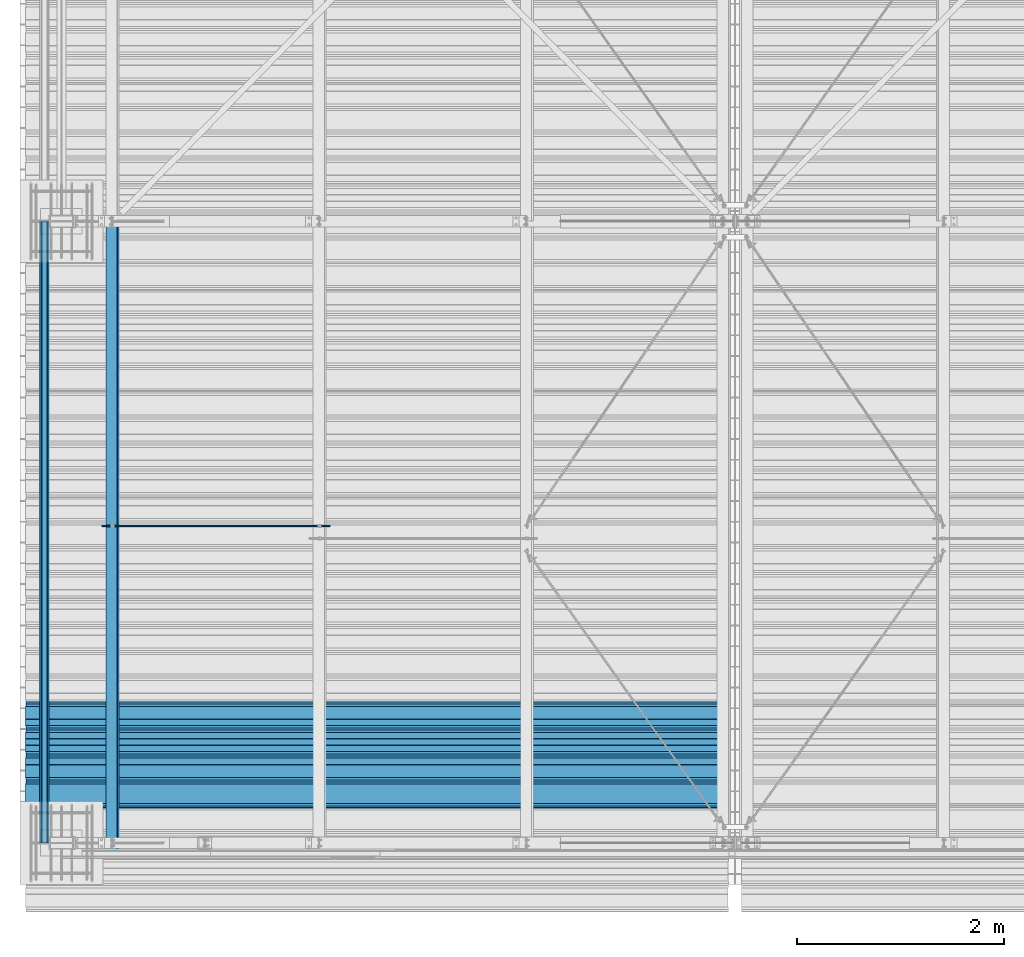
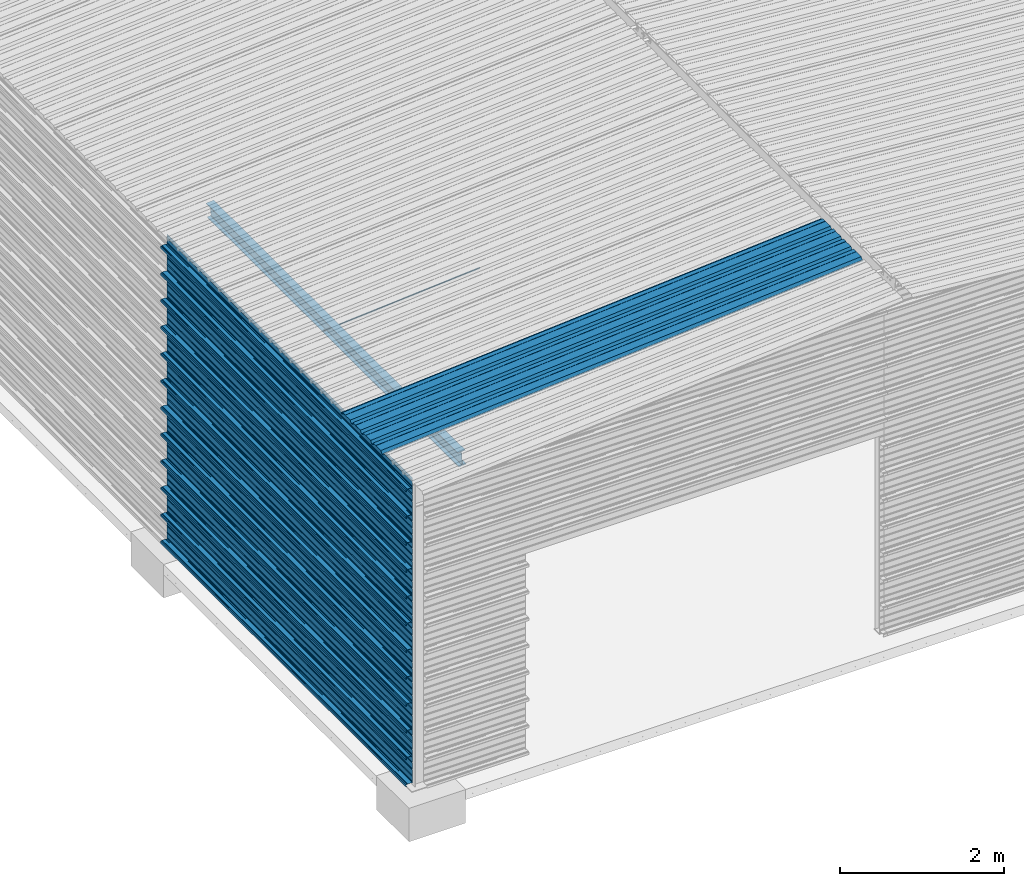
# One storey, part 5 of 70: 15 beams, 15 elements without a shape of their own.
"""IFC2X3 building model written with IfcOpenShell, lengths in millimetres."""

from ifc_helpers import new_model, si_unit, frame, origin_with_axes, origin_2d_with_axis, place, context, subcontext, project, spatial, polyline, circle, i_section, outline, extrude, clip, halfspace, material, type_object, element, aggregate, save


model = new_model("IFC2X3")

# Units and contexts
model_context = context("Model", 3, precision=1e-05, world=origin_with_axes())
body_context = subcontext(model_context, "Body", "Model", "MODEL_VIEW")
ifc_project = project(units=[si_unit("LENGTHUNIT", "METRE", prefix="MILLI"), si_unit("AREAUNIT", "SQUARE_METRE"), si_unit("VOLUMEUNIT", "CUBIC_METRE"), si_unit("MASSUNIT", "GRAM", prefix="KILO"), si_unit("TIMEUNIT", "SECOND"), si_unit("PLANEANGLEUNIT", "RADIAN"), si_unit("SOLIDANGLEUNIT", "STERADIAN"), si_unit("THERMODYNAMICTEMPERATUREUNIT", "DEGREE_CELSIUS"), si_unit("LUMINOUSINTENSITYUNIT", "LUMEN")], contexts=[model_context])

# Site, building, storey
site_placement = place(None, origin_with_axes())
site = spatial("IfcSite", under=ifc_project, at=site_placement, CompositionType="ELEMENT")
building_placement = place(site_placement, origin_with_axes())
building = spatial("IfcBuilding", under=site, at=building_placement, Name="Undefined", CompositionType="ELEMENT")
storey_placement = place(building_placement, origin_with_axes())
storey = spatial("IfcBuildingStorey", under=building, at=storey_placement, Name="Undefined", CompositionType="ELEMENT", Elevation=0.0)

# Assembly, beam
assembly_1_placement = place(storey_placement, origin_with_axes())
assembly_1 = element("IfcElementAssembly", 1, at=assembly_1_placement, inside=storey, Name="Steel Assembly", AssemblyPlace="NOTDEFINED", PredefinedType="RIGID_FRAME")
ifc_material = material(Name="STEEL/S235JR")
beam_type_1 = type_object("IfcBeamType", Name="4.40", PredefinedType="NOTDEFINED")
beam_1_placement = place(assembly_1_placement, frame((6436.39248868039, 850.0, 5336.31760454388), z_axis=(0.0766964990376782, 0.0, -0.997054485489817), x_axis=(-0.997054485489818, 0.0, -0.0766964990376602)))
beam_1 = element("IfcBeam", 2, at=beam_1_placement, type_object=beam_type_1, material=ifc_material, ObjectType="4.40", context=body_context, shape_type="SweptSolid", body=[
    extrude(outline(polyline([(509.415161132813, 19.5000000011705), (490.584838867188, 19.5000000011705), (468.084838867188, -20.4999999988113), (406.585784912109, -20.4999999988113), (404.585784912109, -18.4999999988122), (345.414215087891, -18.4999999988122), (343.414215087891, -20.4999999988113), (281.915161132813, -20.4999999988113), (259.415161132813, 19.5000000011705), (240.584854125977, 19.5000000011705), (218.084854125977, -20.4999999988113), (156.585784912109, -20.4999999988113), (154.585784912109, -18.4999999988122), (95.4142150878906, -18.4999999988122), (93.4142150878906, -20.4999999988113), (31.9151515960693, -20.4999999988113), (9.41515254974365, 19.5000000011705), (-9.41515254974365, 19.5000000011705), (-31.9151515960693, -20.4999999988113), (-93.4142150878906, -20.4999999988113), (-95.4142150878906, -18.4999999988122), (-154.585784912109, -18.4999999988122), (-156.585784912109, -20.4999999988113), (-218.084854125977, -20.4999999988113), (-240.584854125977, 19.5000000011705), (-259.415161132813, 19.5000000011705), (-281.915161132813, -20.4999999988113), (-343.414215087891, -20.4999999988113), (-345.414215087891, -18.4999999988122), (-404.585784912109, -18.4999999988122), (-406.585784912109, -20.4999999988113), (-468.084838867188, -20.4999999988113), (-490.584838867188, 19.5000000011705), (-509.415161132813, 19.5000000011705), (-516.482360839844, 6.9361057293263), (-517.353942871094, 7.42636680720625), (-510.0, 20.5000000011705), (-490.0, 20.5000000011705), (-467.5, -19.4999999988122), (-407.0, -19.4999999988122), (-405.0, -17.4999999988131), (-345.0, -17.4999999988131), (-343.0, -19.4999999988122), (-282.5, -19.4999999988122), (-260.0, 20.5000000011705), (-240.0, 20.5000000011705), (-217.5, -19.4999999988122), (-157.0, -19.4999999988122), (-155.0, -17.4999999988131), (-95.0, -17.4999999988131), (-93.0, -19.4999999988122), (-32.5, -19.4999999988122), (-10.0, 20.5000000011705), (10.0, 20.5000000011705), (32.5, -19.4999999988122), (93.0, -19.4999999988122), (95.0, -17.4999999988131), (155.0, -17.4999999988131), (157.0, -19.4999999988122), (217.5, -19.4999999988122), (240.0, 20.5000000011705), (260.0, 20.5000000011705), (282.5, -19.4999999988122), (343.0, -19.4999999988122), (345.0, -17.4999999988131), (405.0, -17.4999999988131), (407.0, -19.4999999988122), (467.5, -19.4999999988122), (490.0, 20.5000000011705), (510.0, 20.5000000011705), (517.353942871094, 7.42636680720625), (516.482360839844, 6.9361057293263), (509.415161132813, 19.5000000011705)])), frame((6799.99999999733, 2.8421709430404e-14, 0.0), z_axis=(-1.0, 0.0, 0.0), x_axis=(0.0, -1.0, 0.0)), (0.0, 0.0, 1.0), 6800.0),
])
aggregate(assembly_1, [beam_1])

assembly_2_placement = place(storey_placement, origin_with_axes())
assembly_2 = element("IfcElementAssembly", 3, at=assembly_2_placement, inside=storey, Name="Steel Assembly", AssemblyPlace="NOTDEFINED", PredefinedType="RIGID_FRAME")
beam_type_2 = type_object("IfcBeamType", Name="400", PredefinedType="NOTDEFINED")
beam_2_placement = place(assembly_2_placement, frame((-165.499999998334, 3.5811353882309e-12, 4618.17396601053), z_axis=(-1.0, 0.0, 0.0), x_axis=(0.0, 1.0, 0.0)))
beam_2 = element("IfcBeam", 4, at=beam_2_placement, type_object=beam_type_2, material=ifc_material, ObjectType="400", context=body_context, shape_type="Clipping", body=[
    clip(extrude(outline(polyline([(218.25, -24.994083404541), (214.25, -31.8999996185303), (214.25, -45.5), (199.75, -45.5), (194.25, -42.5), (188.75, -45.5), (124.25, -45.5), (114.25, -41.5), (104.25, -45.5), (24.25, -45.5), (14.25, -41.5), (4.25, -45.5), (-75.75, -45.5), (-85.75, -41.5), (-95.75, -45.5), (-160.25, -45.5), (-165.75, -42.5), (-171.25, -45.5), (-185.75, -45.5), (-185.75, -30.711540222168), (-181.75, -23.8111782073975), (-181.75, 23.311637878418), (-185.75, 30.2119998931885), (-185.75, 44.5), (-217.25, 44.5), (-217.25, 34.7999992370605), (-218.25, 34.7999992370605), (-218.25, 45.5), (-184.75, 45.5), (-184.75, 30.480884552002), (-180.75, 23.5805225372314), (-180.75, -24.0800628662109), (-184.75, -30.9804248809814), (-184.75, -44.5), (-171.504989624023, -44.5), (-165.75, -41.360912322998), (-159.995010375977, -44.5), (-95.9425811767578, -44.5), (-85.75, -40.422966003418), (-75.5574188232422, -44.5), (4.05741739273071, -44.5), (14.25, -40.422966003418), (24.4425830841064, -44.5), (104.057418823242, -44.5), (114.25, -40.422966003418), (124.442581176758, -44.5), (188.495010375977, -44.5), (194.25, -41.360912322998), (200.004989624023, -44.5), (213.25, -44.5), (213.25, -31.6313018798828), (217.25, -24.7253856658936), (217.25, 21.7253856658936), (213.25, 28.6313018798828), (213.25, 42.0), (187.25, 42.0), (187.25, 32.5499992370605), (186.25, 32.5499992370605), (186.25, 43.0), (214.25, 43.0), (214.25, 28.8999996185303), (218.25, 21.994083404541), (218.25, -24.994083404541)])), frame((6000.0, 0.0, 0.0), z_axis=(-1.0, 0.0, 0.0), x_axis=(0.0, -1.0, 0.0)), (0.0, 0.0, 1.0), 6000.0), halfspace(frame((5.6843418860808e-14, 36.6804312648874, -45.0000000000003), z_axis=(0.0, -1.0, 0.0), x_axis=(0.0, 0.0, 1.0)), False)),
])
aggregate(assembly_2, [beam_2])

assembly_3_placement = place(storey_placement, origin_with_axes())
assembly_3 = element("IfcElementAssembly", 5, at=assembly_3_placement, inside=storey, Name="Steel Assembly", AssemblyPlace="NOTDEFINED", PredefinedType="RIGID_FRAME")
beam_3_placement = place(assembly_3_placement, frame((-165.499999998485, 3.5811353882309e-12, 4218.17396601053), z_axis=(-1.0, 0.0, 0.0), x_axis=(0.0, 1.0, 0.0)))
beam_3 = element("IfcBeam", 6, at=beam_3_placement, type_object=beam_type_2, material=ifc_material, ObjectType="400", context=body_context, shape_type="SweptSolid", body=[
    extrude(outline(polyline([(218.25, -24.994083404541), (214.25, -31.8999996185303), (214.25, -45.5), (199.75, -45.5), (194.25, -42.5), (188.75, -45.5), (124.25, -45.5), (114.25, -41.5), (104.25, -45.5), (24.25, -45.5), (14.25, -41.5), (4.25, -45.5), (-75.75, -45.5), (-85.75, -41.5), (-95.75, -45.5), (-160.25, -45.5), (-165.75, -42.5), (-171.25, -45.5), (-185.75, -45.5), (-185.75, -30.711540222168), (-181.75, -23.8111782073975), (-181.75, 23.311637878418), (-185.75, 30.2119998931885), (-185.75, 44.5), (-217.25, 44.5), (-217.25, 34.7999992370605), (-218.25, 34.7999992370605), (-218.25, 45.5), (-184.75, 45.5), (-184.75, 30.480884552002), (-180.75, 23.5805225372314), (-180.75, -24.0800628662109), (-184.75, -30.9804248809814), (-184.75, -44.5), (-171.504989624023, -44.5), (-165.75, -41.360912322998), (-159.995010375977, -44.5), (-95.9425811767578, -44.5), (-85.75, -40.422966003418), (-75.5574188232422, -44.5), (4.05741739273071, -44.5), (14.25, -40.422966003418), (24.4425830841064, -44.5), (104.057418823242, -44.5), (114.25, -40.422966003418), (124.442581176758, -44.5), (188.495010375977, -44.5), (194.25, -41.360912322998), (200.004989624023, -44.5), (213.25, -44.5), (213.25, -31.6313018798828), (217.25, -24.7253856658936), (217.25, 21.7253856658936), (213.25, 28.6313018798828), (213.25, 42.0), (187.25, 42.0), (187.25, 32.5499992370605), (186.25, 32.5499992370605), (186.25, 43.0), (214.25, 43.0), (214.25, 28.8999996185303), (218.25, 21.994083404541), (218.25, -24.994083404541)])), frame((6000.0, 0.0, 0.0), z_axis=(-1.0, 0.0, 0.0), x_axis=(0.0, -1.0, 0.0)), (0.0, 0.0, 1.0), 6000.0),
])
aggregate(assembly_3, [beam_3])

assembly_4_placement = place(storey_placement, origin_with_axes())
assembly_4 = element("IfcElementAssembly", 7, at=assembly_4_placement, inside=storey, Name="Steel Assembly", AssemblyPlace="NOTDEFINED", PredefinedType="RIGID_FRAME")
beam_4_placement = place(assembly_4_placement, frame((-165.499999998638, 3.5811353882309e-12, 3818.17396601053), z_axis=(-1.0, 0.0, 0.0), x_axis=(0.0, 1.0, 0.0)))
beam_4 = element("IfcBeam", 8, at=beam_4_placement, type_object=beam_type_2, material=ifc_material, ObjectType="400", context=body_context, shape_type="SweptSolid", body=[
    extrude(outline(polyline([(218.25, -24.994083404541), (214.25, -31.8999996185303), (214.25, -45.5), (199.75, -45.5), (194.25, -42.5), (188.75, -45.5), (124.25, -45.5), (114.25, -41.5), (104.25, -45.5), (24.25, -45.5), (14.25, -41.5), (4.25, -45.5), (-75.75, -45.5), (-85.75, -41.5), (-95.75, -45.5), (-160.25, -45.5), (-165.75, -42.5), (-171.25, -45.5), (-185.75, -45.5), (-185.75, -30.711540222168), (-181.75, -23.8111782073975), (-181.75, 23.311637878418), (-185.75, 30.2119998931885), (-185.75, 44.5), (-217.25, 44.5), (-217.25, 34.7999992370605), (-218.25, 34.7999992370605), (-218.25, 45.5), (-184.75, 45.5), (-184.75, 30.480884552002), (-180.75, 23.5805225372314), (-180.75, -24.0800628662109), (-184.75, -30.9804248809814), (-184.75, -44.5), (-171.504989624023, -44.5), (-165.75, -41.360912322998), (-159.995010375977, -44.5), (-95.9425811767578, -44.5), (-85.75, -40.422966003418), (-75.5574188232422, -44.5), (4.05741739273071, -44.5), (14.25, -40.422966003418), (24.4425830841064, -44.5), (104.057418823242, -44.5), (114.25, -40.422966003418), (124.442581176758, -44.5), (188.495010375977, -44.5), (194.25, -41.360912322998), (200.004989624023, -44.5), (213.25, -44.5), (213.25, -31.6313018798828), (217.25, -24.7253856658936), (217.25, 21.7253856658936), (213.25, 28.6313018798828), (213.25, 42.0), (187.25, 42.0), (187.25, 32.5499992370605), (186.25, 32.5499992370605), (186.25, 43.0), (214.25, 43.0), (214.25, 28.8999996185303), (218.25, 21.994083404541), (218.25, -24.994083404541)])), frame((6000.0, 0.0, 0.0), z_axis=(-1.0, 0.0, 0.0), x_axis=(0.0, -1.0, 0.0)), (0.0, 0.0, 1.0), 6000.0),
])
aggregate(assembly_4, [beam_4])

assembly_5_placement = place(storey_placement, origin_with_axes())
assembly_5 = element("IfcElementAssembly", 9, at=assembly_5_placement, inside=storey, Name="Steel Assembly", AssemblyPlace="NOTDEFINED", PredefinedType="RIGID_FRAME")
beam_5_placement = place(assembly_5_placement, frame((-165.499999998789, 3.5811353882309e-12, 3418.17396601053), z_axis=(-1.0, 0.0, 0.0), x_axis=(0.0, 1.0, 0.0)))
beam_5 = element("IfcBeam", 10, at=beam_5_placement, type_object=beam_type_2, material=ifc_material, ObjectType="400", context=body_context, shape_type="SweptSolid", body=[
    extrude(outline(polyline([(218.25, -24.994083404541), (214.25, -31.8999996185303), (214.25, -45.5), (199.75, -45.5), (194.25, -42.5), (188.75, -45.5), (124.25, -45.5), (114.25, -41.5), (104.25, -45.5), (24.25, -45.5), (14.25, -41.5), (4.25, -45.5), (-75.75, -45.5), (-85.75, -41.5), (-95.75, -45.5), (-160.25, -45.5), (-165.75, -42.5), (-171.25, -45.5), (-185.75, -45.5), (-185.75, -30.711540222168), (-181.75, -23.8111782073975), (-181.75, 23.311637878418), (-185.75, 30.2119998931885), (-185.75, 44.5), (-217.25, 44.5), (-217.25, 34.7999992370605), (-218.25, 34.7999992370605), (-218.25, 45.5), (-184.75, 45.5), (-184.75, 30.480884552002), (-180.75, 23.5805225372314), (-180.75, -24.0800628662109), (-184.75, -30.9804248809814), (-184.75, -44.5), (-171.504989624023, -44.5), (-165.75, -41.360912322998), (-159.995010375977, -44.5), (-95.9425811767578, -44.5), (-85.75, -40.422966003418), (-75.5574188232422, -44.5), (4.05741739273071, -44.5), (14.25, -40.422966003418), (24.4425830841064, -44.5), (104.057418823242, -44.5), (114.25, -40.422966003418), (124.442581176758, -44.5), (188.495010375977, -44.5), (194.25, -41.360912322998), (200.004989624023, -44.5), (213.25, -44.5), (213.25, -31.6313018798828), (217.25, -24.7253856658936), (217.25, 21.7253856658936), (213.25, 28.6313018798828), (213.25, 42.0), (187.25, 42.0), (187.25, 32.5499992370605), (186.25, 32.5499992370605), (186.25, 43.0), (214.25, 43.0), (214.25, 28.8999996185303), (218.25, 21.994083404541), (218.25, -24.994083404541)])), frame((6000.0, 0.0, 0.0), z_axis=(-1.0, 0.0, 0.0), x_axis=(0.0, -1.0, 0.0)), (0.0, 0.0, 1.0), 6000.0),
])
aggregate(assembly_5, [beam_5])

assembly_6_placement = place(storey_placement, origin_with_axes())
assembly_6 = element("IfcElementAssembly", 11, at=assembly_6_placement, inside=storey, Name="Steel Assembly", AssemblyPlace="NOTDEFINED", PredefinedType="RIGID_FRAME")
beam_6_placement = place(assembly_6_placement, frame((-165.49999999894, 3.5811353882309e-12, 3018.17396601053), z_axis=(-1.0, 0.0, 0.0), x_axis=(0.0, 1.0, 0.0)))
beam_6 = element("IfcBeam", 12, at=beam_6_placement, type_object=beam_type_2, material=ifc_material, ObjectType="400", context=body_context, shape_type="SweptSolid", body=[
    extrude(outline(polyline([(218.25, -24.994083404541), (214.25, -31.8999996185303), (214.25, -45.5), (199.75, -45.5), (194.25, -42.5), (188.75, -45.5), (124.25, -45.5), (114.25, -41.5), (104.25, -45.5), (24.25, -45.5), (14.25, -41.5), (4.25, -45.5), (-75.75, -45.5), (-85.75, -41.5), (-95.75, -45.5), (-160.25, -45.5), (-165.75, -42.5), (-171.25, -45.5), (-185.75, -45.5), (-185.75, -30.711540222168), (-181.75, -23.8111782073975), (-181.75, 23.311637878418), (-185.75, 30.2119998931885), (-185.75, 44.5), (-217.25, 44.5), (-217.25, 34.7999992370605), (-218.25, 34.7999992370605), (-218.25, 45.5), (-184.75, 45.5), (-184.75, 30.480884552002), (-180.75, 23.5805225372314), (-180.75, -24.0800628662109), (-184.75, -30.9804248809814), (-184.75, -44.5), (-171.504989624023, -44.5), (-165.75, -41.360912322998), (-159.995010375977, -44.5), (-95.9425811767578, -44.5), (-85.75, -40.422966003418), (-75.5574188232422, -44.5), (4.05741739273071, -44.5), (14.25, -40.422966003418), (24.4425830841064, -44.5), (104.057418823242, -44.5), (114.25, -40.422966003418), (124.442581176758, -44.5), (188.495010375977, -44.5), (194.25, -41.360912322998), (200.004989624023, -44.5), (213.25, -44.5), (213.25, -31.6313018798828), (217.25, -24.7253856658936), (217.25, 21.7253856658936), (213.25, 28.6313018798828), (213.25, 42.0), (187.25, 42.0), (187.25, 32.5499992370605), (186.25, 32.5499992370605), (186.25, 43.0), (214.25, 43.0), (214.25, 28.8999996185303), (218.25, 21.994083404541), (218.25, -24.994083404541)])), frame((6000.0, 0.0, 0.0), z_axis=(-1.0, 0.0, 0.0), x_axis=(0.0, -1.0, 0.0)), (0.0, 0.0, 1.0), 6000.0),
])
aggregate(assembly_6, [beam_6])

assembly_7_placement = place(storey_placement, origin_with_axes())
assembly_7 = element("IfcElementAssembly", 13, at=assembly_7_placement, inside=storey, Name="Steel Assembly", AssemblyPlace="NOTDEFINED", PredefinedType="RIGID_FRAME")
beam_7_placement = place(assembly_7_placement, frame((-165.499999999092, 3.5811353882309e-12, 2618.17396601053), z_axis=(-1.0, 0.0, 0.0), x_axis=(0.0, 1.0, 0.0)))
beam_7 = element("IfcBeam", 14, at=beam_7_placement, type_object=beam_type_2, material=ifc_material, ObjectType="400", context=body_context, shape_type="SweptSolid", body=[
    extrude(outline(polyline([(218.25, -24.994083404541), (214.25, -31.8999996185303), (214.25, -45.5), (199.75, -45.5), (194.25, -42.5), (188.75, -45.5), (124.25, -45.5), (114.25, -41.5), (104.25, -45.5), (24.25, -45.5), (14.25, -41.5), (4.25, -45.5), (-75.75, -45.5), (-85.75, -41.5), (-95.75, -45.5), (-160.25, -45.5), (-165.75, -42.5), (-171.25, -45.5), (-185.75, -45.5), (-185.75, -30.711540222168), (-181.75, -23.8111782073975), (-181.75, 23.311637878418), (-185.75, 30.2119998931885), (-185.75, 44.5), (-217.25, 44.5), (-217.25, 34.7999992370605), (-218.25, 34.7999992370605), (-218.25, 45.5), (-184.75, 45.5), (-184.75, 30.480884552002), (-180.75, 23.5805225372314), (-180.75, -24.0800628662109), (-184.75, -30.9804248809814), (-184.75, -44.5), (-171.504989624023, -44.5), (-165.75, -41.360912322998), (-159.995010375977, -44.5), (-95.9425811767578, -44.5), (-85.75, -40.422966003418), (-75.5574188232422, -44.5), (4.05741739273071, -44.5), (14.25, -40.422966003418), (24.4425830841064, -44.5), (104.057418823242, -44.5), (114.25, -40.422966003418), (124.442581176758, -44.5), (188.495010375977, -44.5), (194.25, -41.360912322998), (200.004989624023, -44.5), (213.25, -44.5), (213.25, -31.6313018798828), (217.25, -24.7253856658936), (217.25, 21.7253856658936), (213.25, 28.6313018798828), (213.25, 42.0), (187.25, 42.0), (187.25, 32.5499992370605), (186.25, 32.5499992370605), (186.25, 43.0), (214.25, 43.0), (214.25, 28.8999996185303), (218.25, 21.994083404541), (218.25, -24.994083404541)])), frame((6000.0, 0.0, 0.0), z_axis=(-1.0, 0.0, 0.0), x_axis=(0.0, -1.0, 0.0)), (0.0, 0.0, 1.0), 6000.0),
])
aggregate(assembly_7, [beam_7])

assembly_8_placement = place(storey_placement, origin_with_axes())
assembly_8 = element("IfcElementAssembly", 15, at=assembly_8_placement, inside=storey, Name="Steel Assembly", AssemblyPlace="NOTDEFINED", PredefinedType="RIGID_FRAME")
beam_8_placement = place(assembly_8_placement, frame((-165.499999999243, 3.5811353882309e-12, 2218.17396601053), z_axis=(-1.0, 0.0, 0.0), x_axis=(0.0, 1.0, 0.0)))
beam_8 = element("IfcBeam", 16, at=beam_8_placement, type_object=beam_type_2, material=ifc_material, ObjectType="400", context=body_context, shape_type="SweptSolid", body=[
    extrude(outline(polyline([(218.25, -24.994083404541), (214.25, -31.8999996185303), (214.25, -45.5), (199.75, -45.5), (194.25, -42.5), (188.75, -45.5), (124.25, -45.5), (114.25, -41.5), (104.25, -45.5), (24.25, -45.5), (14.25, -41.5), (4.25, -45.5), (-75.75, -45.5), (-85.75, -41.5), (-95.75, -45.5), (-160.25, -45.5), (-165.75, -42.5), (-171.25, -45.5), (-185.75, -45.5), (-185.75, -30.711540222168), (-181.75, -23.8111782073975), (-181.75, 23.311637878418), (-185.75, 30.2119998931885), (-185.75, 44.5), (-217.25, 44.5), (-217.25, 34.7999992370605), (-218.25, 34.7999992370605), (-218.25, 45.5), (-184.75, 45.5), (-184.75, 30.480884552002), (-180.75, 23.5805225372314), (-180.75, -24.0800628662109), (-184.75, -30.9804248809814), (-184.75, -44.5), (-171.504989624023, -44.5), (-165.75, -41.360912322998), (-159.995010375977, -44.5), (-95.9425811767578, -44.5), (-85.75, -40.422966003418), (-75.5574188232422, -44.5), (4.05741739273071, -44.5), (14.25, -40.422966003418), (24.4425830841064, -44.5), (104.057418823242, -44.5), (114.25, -40.422966003418), (124.442581176758, -44.5), (188.495010375977, -44.5), (194.25, -41.360912322998), (200.004989624023, -44.5), (213.25, -44.5), (213.25, -31.6313018798828), (217.25, -24.7253856658936), (217.25, 21.7253856658936), (213.25, 28.6313018798828), (213.25, 42.0), (187.25, 42.0), (187.25, 32.5499992370605), (186.25, 32.5499992370605), (186.25, 43.0), (214.25, 43.0), (214.25, 28.8999996185303), (218.25, 21.994083404541), (218.25, -24.994083404541)])), frame((6000.0, 0.0, 0.0), z_axis=(-1.0, 0.0, 0.0), x_axis=(0.0, -1.0, 0.0)), (0.0, 0.0, 1.0), 6000.0),
])
aggregate(assembly_8, [beam_8])

assembly_9_placement = place(storey_placement, origin_with_axes())
assembly_9 = element("IfcElementAssembly", 17, at=assembly_9_placement, inside=storey, Name="Steel Assembly", AssemblyPlace="NOTDEFINED", PredefinedType="RIGID_FRAME")
beam_9_placement = place(assembly_9_placement, frame((-165.499999999396, 3.5811353882309e-12, 1818.17396601053), z_axis=(-1.0, 0.0, 0.0), x_axis=(0.0, 1.0, 0.0)))
beam_9 = element("IfcBeam", 18, at=beam_9_placement, type_object=beam_type_2, material=ifc_material, ObjectType="400", context=body_context, shape_type="SweptSolid", body=[
    extrude(outline(polyline([(218.25, -24.994083404541), (214.25, -31.8999996185303), (214.25, -45.5), (199.75, -45.5), (194.25, -42.5), (188.75, -45.5), (124.25, -45.5), (114.25, -41.5), (104.25, -45.5), (24.25, -45.5), (14.25, -41.5), (4.25, -45.5), (-75.75, -45.5), (-85.75, -41.5), (-95.75, -45.5), (-160.25, -45.5), (-165.75, -42.5), (-171.25, -45.5), (-185.75, -45.5), (-185.75, -30.711540222168), (-181.75, -23.8111782073975), (-181.75, 23.311637878418), (-185.75, 30.2119998931885), (-185.75, 44.5), (-217.25, 44.5), (-217.25, 34.7999992370605), (-218.25, 34.7999992370605), (-218.25, 45.5), (-184.75, 45.5), (-184.75, 30.480884552002), (-180.75, 23.5805225372314), (-180.75, -24.0800628662109), (-184.75, -30.9804248809814), (-184.75, -44.5), (-171.504989624023, -44.5), (-165.75, -41.360912322998), (-159.995010375977, -44.5), (-95.9425811767578, -44.5), (-85.75, -40.422966003418), (-75.5574188232422, -44.5), (4.05741739273071, -44.5), (14.25, -40.422966003418), (24.4425830841064, -44.5), (104.057418823242, -44.5), (114.25, -40.422966003418), (124.442581176758, -44.5), (188.495010375977, -44.5), (194.25, -41.360912322998), (200.004989624023, -44.5), (213.25, -44.5), (213.25, -31.6313018798828), (217.25, -24.7253856658936), (217.25, 21.7253856658936), (213.25, 28.6313018798828), (213.25, 42.0), (187.25, 42.0), (187.25, 32.5499992370605), (186.25, 32.5499992370605), (186.25, 43.0), (214.25, 43.0), (214.25, 28.8999996185303), (218.25, 21.994083404541), (218.25, -24.994083404541)])), frame((6000.0, 0.0, 0.0), z_axis=(-1.0, 0.0, 0.0), x_axis=(0.0, -1.0, 0.0)), (0.0, 0.0, 1.0), 6000.0),
])
aggregate(assembly_9, [beam_9])

assembly_10_placement = place(storey_placement, origin_with_axes())
assembly_10 = element("IfcElementAssembly", 19, at=assembly_10_placement, inside=storey, Name="Steel Assembly", AssemblyPlace="NOTDEFINED", PredefinedType="RIGID_FRAME")
beam_10_placement = place(assembly_10_placement, frame((-165.499999999547, 3.5811353882309e-12, 1418.17396601053), z_axis=(-1.0, 0.0, 0.0), x_axis=(0.0, 1.0, 0.0)))
beam_10 = element("IfcBeam", 20, at=beam_10_placement, type_object=beam_type_2, material=ifc_material, ObjectType="400", context=body_context, shape_type="SweptSolid", body=[
    extrude(outline(polyline([(218.25, -24.994083404541), (214.25, -31.8999996185303), (214.25, -45.5), (199.75, -45.5), (194.25, -42.5), (188.75, -45.5), (124.25, -45.5), (114.25, -41.5), (104.25, -45.5), (24.25, -45.5), (14.25, -41.5), (4.25, -45.5), (-75.75, -45.5), (-85.75, -41.5), (-95.75, -45.5), (-160.25, -45.5), (-165.75, -42.5), (-171.25, -45.5), (-185.75, -45.5), (-185.75, -30.711540222168), (-181.75, -23.8111782073975), (-181.75, 23.311637878418), (-185.75, 30.2119998931885), (-185.75, 44.5), (-217.25, 44.5), (-217.25, 34.7999992370605), (-218.25, 34.7999992370605), (-218.25, 45.5), (-184.75, 45.5), (-184.75, 30.480884552002), (-180.75, 23.5805225372314), (-180.75, -24.0800628662109), (-184.75, -30.9804248809814), (-184.75, -44.5), (-171.504989624023, -44.5), (-165.75, -41.360912322998), (-159.995010375977, -44.5), (-95.9425811767578, -44.5), (-85.75, -40.422966003418), (-75.5574188232422, -44.5), (4.05741739273071, -44.5), (14.25, -40.422966003418), (24.4425830841064, -44.5), (104.057418823242, -44.5), (114.25, -40.422966003418), (124.442581176758, -44.5), (188.495010375977, -44.5), (194.25, -41.360912322998), (200.004989624023, -44.5), (213.25, -44.5), (213.25, -31.6313018798828), (217.25, -24.7253856658936), (217.25, 21.7253856658936), (213.25, 28.6313018798828), (213.25, 42.0), (187.25, 42.0), (187.25, 32.5499992370605), (186.25, 32.5499992370605), (186.25, 43.0), (214.25, 43.0), (214.25, 28.8999996185303), (218.25, 21.994083404541), (218.25, -24.994083404541)])), frame((6000.0, 0.0, 0.0), z_axis=(-1.0, 0.0, 0.0), x_axis=(0.0, -1.0, 0.0)), (0.0, 0.0, 1.0), 6000.0),
])
aggregate(assembly_10, [beam_10])

assembly_11_placement = place(storey_placement, origin_with_axes())
assembly_11 = element("IfcElementAssembly", 21, at=assembly_11_placement, inside=storey, Name="Steel Assembly", AssemblyPlace="NOTDEFINED", PredefinedType="RIGID_FRAME")
beam_11_placement = place(assembly_11_placement, frame((-165.499999999698, 3.5811353882309e-12, 1018.17396601053), z_axis=(-1.0, 0.0, 0.0), x_axis=(0.0, 1.0, 0.0)))
beam_11 = element("IfcBeam", 22, at=beam_11_placement, type_object=beam_type_2, material=ifc_material, ObjectType="400", context=body_context, shape_type="SweptSolid", body=[
    extrude(outline(polyline([(218.25, -24.994083404541), (214.25, -31.8999996185303), (214.25, -45.5), (199.75, -45.5), (194.25, -42.5), (188.75, -45.5), (124.25, -45.5), (114.25, -41.5), (104.25, -45.5), (24.25, -45.5), (14.25, -41.5), (4.25, -45.5), (-75.75, -45.5), (-85.75, -41.5), (-95.75, -45.5), (-160.25, -45.5), (-165.75, -42.5), (-171.25, -45.5), (-185.75, -45.5), (-185.75, -30.711540222168), (-181.75, -23.8111782073975), (-181.75, 23.311637878418), (-185.75, 30.2119998931885), (-185.75, 44.5), (-217.25, 44.5), (-217.25, 34.7999992370605), (-218.25, 34.7999992370605), (-218.25, 45.5), (-184.75, 45.5), (-184.75, 30.480884552002), (-180.75, 23.5805225372314), (-180.75, -24.0800628662109), (-184.75, -30.9804248809814), (-184.75, -44.5), (-171.504989624023, -44.5), (-165.75, -41.360912322998), (-159.995010375977, -44.5), (-95.9425811767578, -44.5), (-85.75, -40.422966003418), (-75.5574188232422, -44.5), (4.05741739273071, -44.5), (14.25, -40.422966003418), (24.4425830841064, -44.5), (104.057418823242, -44.5), (114.25, -40.422966003418), (124.442581176758, -44.5), (188.495010375977, -44.5), (194.25, -41.360912322998), (200.004989624023, -44.5), (213.25, -44.5), (213.25, -31.6313018798828), (217.25, -24.7253856658936), (217.25, 21.7253856658936), (213.25, 28.6313018798828), (213.25, 42.0), (187.25, 42.0), (187.25, 32.5499992370605), (186.25, 32.5499992370605), (186.25, 43.0), (214.25, 43.0), (214.25, 28.8999996185303), (218.25, 21.994083404541), (218.25, -24.994083404541)])), frame((6000.0, 0.0, 0.0), z_axis=(-1.0, 0.0, 0.0), x_axis=(0.0, -1.0, 0.0)), (0.0, 0.0, 1.0), 6000.0),
])
aggregate(assembly_11, [beam_11])

assembly_12_placement = place(storey_placement, origin_with_axes())
assembly_12 = element("IfcElementAssembly", 23, at=assembly_12_placement, inside=storey, Name="Steel Assembly", AssemblyPlace="NOTDEFINED", PredefinedType="RIGID_FRAME")
beam_12_placement = place(assembly_12_placement, frame((-165.499999999851, 3.5811353882309e-12, 618.173966010527), z_axis=(-1.0, 0.0, 0.0), x_axis=(0.0, 1.0, 0.0)))
beam_12 = element("IfcBeam", 24, at=beam_12_placement, type_object=beam_type_2, material=ifc_material, ObjectType="400", context=body_context, shape_type="SweptSolid", body=[
    extrude(outline(polyline([(218.25, -24.994083404541), (214.25, -31.8999996185303), (214.25, -45.5), (199.75, -45.5), (194.25, -42.5), (188.75, -45.5), (124.25, -45.5), (114.25, -41.5), (104.25, -45.5), (24.25, -45.5), (14.25, -41.5), (4.25, -45.5), (-75.75, -45.5), (-85.75, -41.5), (-95.75, -45.5), (-160.25, -45.5), (-165.75, -42.5), (-171.25, -45.5), (-185.75, -45.5), (-185.75, -30.711540222168), (-181.75, -23.8111782073975), (-181.75, 23.311637878418), (-185.75, 30.2119998931885), (-185.75, 44.5), (-217.25, 44.5), (-217.25, 34.7999992370605), (-218.25, 34.7999992370605), (-218.25, 45.5), (-184.75, 45.5), (-184.75, 30.480884552002), (-180.75, 23.5805225372314), (-180.75, -24.0800628662109), (-184.75, -30.9804248809814), (-184.75, -44.5), (-171.504989624023, -44.5), (-165.75, -41.360912322998), (-159.995010375977, -44.5), (-95.9425811767578, -44.5), (-85.75, -40.422966003418), (-75.5574188232422, -44.5), (4.05741739273071, -44.5), (14.25, -40.422966003418), (24.4425830841064, -44.5), (104.057418823242, -44.5), (114.25, -40.422966003418), (124.442581176758, -44.5), (188.495010375977, -44.5), (194.25, -41.360912322998), (200.004989624023, -44.5), (213.25, -44.5), (213.25, -31.6313018798828), (217.25, -24.7253856658936), (217.25, 21.7253856658936), (213.25, 28.6313018798828), (213.25, 42.0), (187.25, 42.0), (187.25, 32.5499992370605), (186.25, 32.5499992370605), (186.25, 43.0), (214.25, 43.0), (214.25, 28.8999996185303), (218.25, 21.994083404541), (218.25, -24.994083404541)])), frame((6000.0, 0.0, 0.0), z_axis=(-1.0, 0.0, 0.0), x_axis=(0.0, -1.0, 0.0)), (0.0, 0.0, 1.0), 6000.0),
])
aggregate(assembly_12, [beam_12])

assembly_13_placement = place(storey_placement, origin_with_axes())
assembly_13 = element("IfcElementAssembly", 25, at=assembly_13_placement, inside=storey, Name="Steel Assembly", AssemblyPlace="NOTDEFINED", PredefinedType="RIGID_FRAME")
beam_13_placement = place(assembly_13_placement, frame((-165.500000000002, 3.5811353882309e-12, 218.173966010527), z_axis=(-1.0, 0.0, 0.0), x_axis=(0.0, 1.0, 0.0)))
beam_13 = element("IfcBeam", 26, at=beam_13_placement, type_object=beam_type_2, material=ifc_material, ObjectType="400", context=body_context, shape_type="SweptSolid", body=[
    extrude(outline(polyline([(218.25, -24.994083404541), (214.25, -31.8999996185303), (214.25, -45.5), (199.75, -45.5), (194.25, -42.5), (188.75, -45.5), (124.25, -45.5), (114.25, -41.5), (104.25, -45.5), (24.25, -45.5), (14.25, -41.5), (4.25, -45.5), (-75.75, -45.5), (-85.75, -41.5), (-95.75, -45.5), (-160.25, -45.5), (-165.75, -42.5), (-171.25, -45.5), (-185.75, -45.5), (-185.75, -30.711540222168), (-181.75, -23.8111782073975), (-181.75, 23.311637878418), (-185.75, 30.2119998931885), (-185.75, 44.5), (-217.25, 44.5), (-217.25, 34.7999992370605), (-218.25, 34.7999992370605), (-218.25, 45.5), (-184.75, 45.5), (-184.75, 30.480884552002), (-180.75, 23.5805225372314), (-180.75, -24.0800628662109), (-184.75, -30.9804248809814), (-184.75, -44.5), (-171.504989624023, -44.5), (-165.75, -41.360912322998), (-159.995010375977, -44.5), (-95.9425811767578, -44.5), (-85.75, -40.422966003418), (-75.5574188232422, -44.5), (4.05741739273071, -44.5), (14.25, -40.422966003418), (24.4425830841064, -44.5), (104.057418823242, -44.5), (114.25, -40.422966003418), (124.442581176758, -44.5), (188.495010375977, -44.5), (194.25, -41.360912322998), (200.004989624023, -44.5), (213.25, -44.5), (213.25, -31.6313018798828), (217.25, -24.7253856658936), (217.25, 21.7253856658936), (213.25, 28.6313018798828), (213.25, 42.0), (187.25, 42.0), (187.25, 32.5499992370605), (186.25, 32.5499992370605), (186.25, 43.0), (214.25, 43.0), (214.25, 28.8999996185303), (218.25, 21.994083404541), (218.25, -24.994083404541)])), frame((6000.0, 0.0, 0.0), z_axis=(-1.0, 0.0, 0.0), x_axis=(0.0, -1.0, 0.0)), (0.0, 0.0, 1.0), 6000.0),
])
aggregate(assembly_13, [beam_13])

assembly_14_placement = place(storey_placement, origin_with_axes())
assembly_14 = element("IfcElementAssembly", 27, at=assembly_14_placement, inside=storey, Name="Steel Assembly", AssemblyPlace="NOTDEFINED", PredefinedType="RIGID_FRAME")
beam_type_3 = type_object("IfcBeamType", Name="D14", PredefinedType="NOTDEFINED")
beam_14_placement = place(assembly_14_placement, frame((2591.26883365322, 3060.00000000009, 4909.65333500212), z_axis=(0.0766964990376782, 0.0, -0.997054485489817), x_axis=(-0.997054485489818, 0.0, -0.0766964990376602)))
beam_14 = element("IfcBeam", 28, at=beam_14_placement, type_object=beam_type_3, material=ifc_material, Name="THREAD60MM", ObjectType="D14", context=body_context, shape_type="SweptSolid", body=[
    extrude(circle(Radius=7.0, at=origin_2d_with_axis()), frame((2205.90843239298, 9.09494701772928e-13, -9.40107830921147e-13), z_axis=(-1.0, 0.0, 0.0), x_axis=(0.0, -1.0, 0.0)), (0.0, 0.0, 1.0), 2205.91),
])
aggregate(assembly_14, [beam_14])

assembly_15_placement = place(storey_placement, origin_with_axes())
assembly_15 = element("IfcElementAssembly", 29, at=assembly_15_placement, inside=storey, Name="Steel Assembly", AssemblyPlace="NOTDEFINED", PredefinedType="RIGID_FRAME")
beam_type_4 = type_object("IfcBeamType", Name="IPE220", PredefinedType="NOTDEFINED")
beam_15_placement = place(assembly_15_placement, frame((491.563385105986, 5999.99999999999, 4748.13753191124), z_axis=(-0.0766964990376602, 0.0, 0.997054485489818), x_axis=(0.0, -1.0, 0.0)))
beam_15 = element("IfcBeam", 30, at=beam_15_placement, type_object=beam_type_4, material=ifc_material, ObjectType="IPE220", context=body_context, shape_type="Clipping", body=[
    clip(extrude(i_section(OverallWidth=110.0, OverallDepth=220.0, WebThickness=5.900000095, FlangeThickness=9.199999809, FilletRadius=12.0, at=origin_2d_with_axis()), frame((6150.0000000001, 0.0, 0.0), z_axis=(-1.0, 0.0, 0.0), x_axis=(0.0, -1.0, 0.0)), (0.0, 0.0, 1.0), 6145.0), halfspace(frame((4.99999999999636, 7.09405867382884e-11, -1.79170456249267e-10), z_axis=(1.0, 0.0, 0.0), x_axis=(0.0, -1.0, 0.0)), True)),
])
aggregate(assembly_15, [beam_15])

save(model, "model.ifc")
